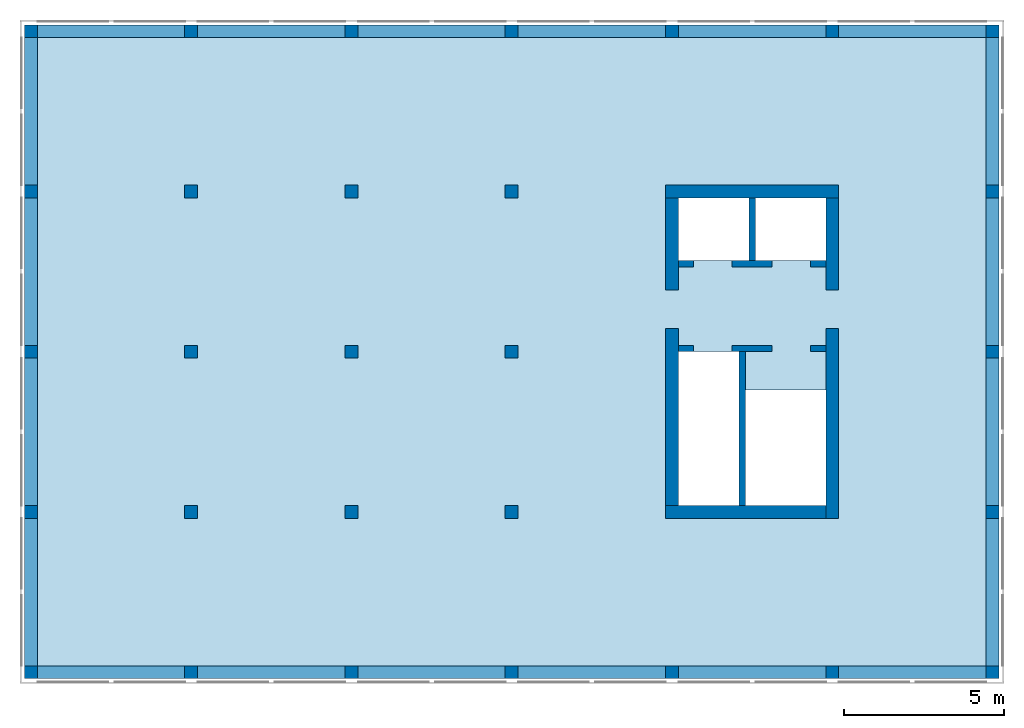
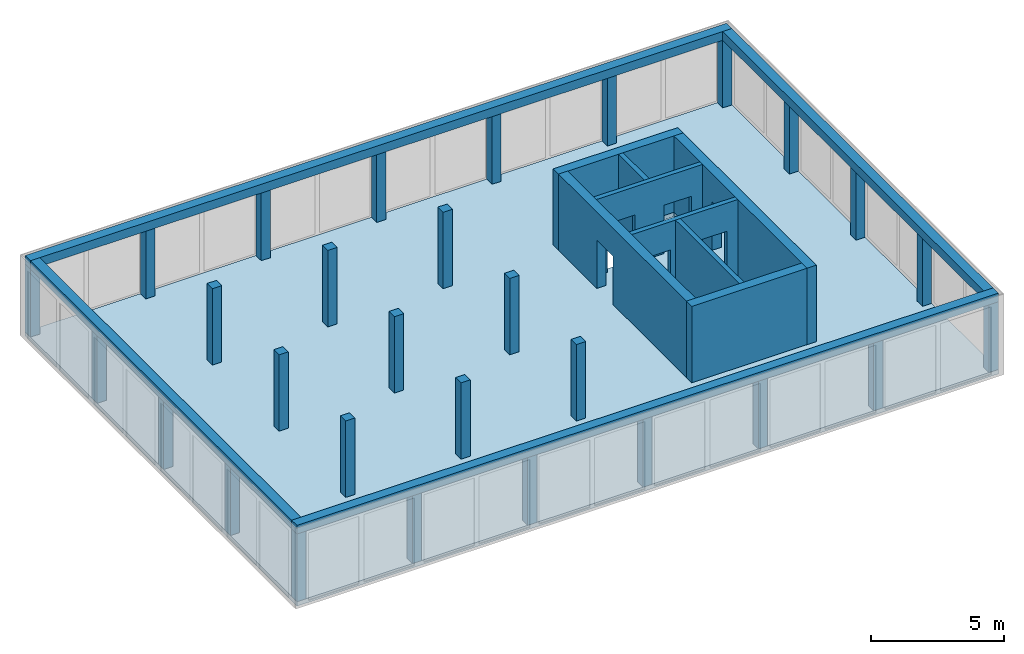
# One storey, part 1 of 3: 29 columns, 8 walls, 4 beams, 1 slab, 9 openings.
"""IFC2X3 building model written with IfcOpenShell, lengths in metres."""

from ifc_helpers import new_model, entity, si_unit, converted_unit, frame, frame_2d, origin, origin_with_axes, place, context, subcontext, project, spatial, polyline, rectangle, outline, extrude, material, layer, layer_set, layer_usage, element, save


model = new_model("IFC2X3")

# Units and contexts
model_context = context("Model", 3, precision=1e-05, world=origin())
body_context = subcontext(model_context, "Body", "Model", "MODEL_VIEW")
ifc_project = project(units=[si_unit("LENGTHUNIT", "METRE"), si_unit("AREAUNIT", "SQUARE_METRE"), si_unit("VOLUMEUNIT", "CUBIC_METRE"), si_unit("MASSUNIT", "GRAM", prefix="KILO"), converted_unit("PLANEANGLEUNIT", "DEGREE", entity("IfcPlaneAngleMeasure", 0.0174532925199433), si_unit("PLANEANGLEUNIT", "RADIAN"), dimensions=[0, 0, 0, 0, 0, 0, 0])], contexts=[model_context])

# Site, building, storey
site_placement = place(None, origin())
site = spatial("IfcSite", under=ifc_project, at=site_placement, CompositionType="ELEMENT")
building_placement = place(site_placement, origin())
building = spatial("IfcBuilding", under=site, at=building_placement, CompositionType="ELEMENT")
storey_placement = place(building_placement, frame((0.0, 0.0, 16.0)))
storey = spatial("IfcBuildingStorey", under=building, at=storey_placement, Name="4. Obergeschoss", CompositionType="ELEMENT", Elevation=16.0)

# Columns
ifc_material_1 = material(Name="C30/37")
column_1_placement = place(storey_placement, frame((5.0, 5.0, 0.0)))
element("IfcColumn", 1, at=column_1_placement, inside=storey, material=ifc_material_1, context=body_context, shape_type="SweptSolid", body=[
    extrude(rectangle(XDim=0.4, YDim=0.4, at=frame_2d((0.2, 0.2), x_axis=(1.0, 0.0))), origin_with_axes(), (0.0, 0.0, 1.0), 3.5),
])
ifc_material_2 = material(Name="C30/37")
column_2_placement = place(storey_placement, frame((15.0, 15.0, 0.0)))
element("IfcColumn", 2, at=column_2_placement, inside=storey, material=ifc_material_2, context=body_context, shape_type="SweptSolid", body=[
    extrude(rectangle(XDim=0.4, YDim=0.4, at=frame_2d((0.2, 0.2), x_axis=(1.0, 0.0))), origin_with_axes(), (0.0, 0.0, 1.0), 3.5),
])
ifc_material_3 = material(Name="C30/37")
column_3_placement = place(storey_placement, frame((10.0, 15.0, 0.0)))
element("IfcColumn", 3, at=column_3_placement, inside=storey, material=ifc_material_3, context=body_context, shape_type="SweptSolid", body=[
    extrude(rectangle(XDim=0.4, YDim=0.4, at=frame_2d((0.2, 0.2), x_axis=(1.0, 0.0))), origin_with_axes(), (0.0, 0.0, 1.0), 3.5),
])
ifc_material_4 = material(Name="C30/37")
column_4_placement = place(storey_placement, frame((5.0, 15.0, 0.0)))
element("IfcColumn", 4, at=column_4_placement, inside=storey, material=ifc_material_4, context=body_context, shape_type="SweptSolid", body=[
    extrude(rectangle(XDim=0.4, YDim=0.4, at=frame_2d((0.2, 0.2), x_axis=(1.0, 0.0))), origin_with_axes(), (0.0, 0.0, 1.0), 3.5),
])
ifc_material_5 = material(Name="C30/37")
column_5_placement = place(storey_placement, frame((15.0, 10.0, 0.0)))
element("IfcColumn", 5, at=column_5_placement, inside=storey, material=ifc_material_5, context=body_context, shape_type="SweptSolid", body=[
    extrude(rectangle(XDim=0.4, YDim=0.4, at=frame_2d((0.2, 0.2), x_axis=(1.0, 0.0))), origin_with_axes(), (0.0, 0.0, 1.0), 3.5),
])
ifc_material_6 = material(Name="C30/37")
column_6_placement = place(storey_placement, frame((10.0, 10.0, 0.0)))
element("IfcColumn", 6, at=column_6_placement, inside=storey, material=ifc_material_6, context=body_context, shape_type="SweptSolid", body=[
    extrude(rectangle(XDim=0.4, YDim=0.4, at=frame_2d((0.2, 0.2), x_axis=(1.0, 0.0))), origin_with_axes(), (0.0, 0.0, 1.0), 3.5),
])
ifc_material_7 = material(Name="C30/37")
column_7_placement = place(storey_placement, frame((5.0, 10.0, 0.0)))
element("IfcColumn", 7, at=column_7_placement, inside=storey, material=ifc_material_7, context=body_context, shape_type="SweptSolid", body=[
    extrude(rectangle(XDim=0.4, YDim=0.4, at=frame_2d((0.2, 0.2), x_axis=(1.0, 0.0))), origin_with_axes(), (0.0, 0.0, 1.0), 3.5),
])
ifc_material_8 = material(Name="C30/37")
column_8_placement = place(storey_placement, frame((15.0, 5.0, 0.0)))
element("IfcColumn", 8, at=column_8_placement, inside=storey, material=ifc_material_8, context=body_context, shape_type="SweptSolid", body=[
    extrude(rectangle(XDim=0.4, YDim=0.4, at=frame_2d((0.2, 0.2), x_axis=(1.0, 0.0))), origin_with_axes(), (0.0, 0.0, 1.0), 3.5),
])
ifc_material_9 = material(Name="C30/37")
column_9_placement = place(storey_placement, frame((10.0, 5.0, 0.0)))
element("IfcColumn", 9, at=column_9_placement, inside=storey, material=ifc_material_9, context=body_context, shape_type="SweptSolid", body=[
    extrude(rectangle(XDim=0.4, YDim=0.4, at=frame_2d((0.2, 0.2), x_axis=(1.0, 0.0))), origin_with_axes(), (0.0, 0.0, 1.0), 3.5),
])
ifc_material_10 = material(Name="C30/37")
column_10_placement = place(storey_placement, frame((-1.27897692436818e-15, 10.0, 0.0)))
element("IfcColumn", 10, at=column_10_placement, inside=storey, material=ifc_material_10, context=body_context, shape_type="SweptSolid", body=[
    extrude(rectangle(XDim=0.400000000000003, YDim=0.4, at=frame_2d((0.200000000000001, 0.2), x_axis=(1.0, 0.0))), origin_with_axes(), (0.0, 0.0, 1.0), 3.1),
])
ifc_material_11 = material(Name="C30/37")
column_11_placement = place(storey_placement, origin())
element("IfcColumn", 11, at=column_11_placement, inside=storey, material=ifc_material_11, context=body_context, shape_type="SweptSolid", body=[
    extrude(rectangle(XDim=0.4, YDim=0.4, at=frame_2d((0.2, 0.2), x_axis=(1.0, 0.0))), origin_with_axes(), (0.0, 0.0, 1.0), 3.1),
])
ifc_material_12 = material(Name="C30/37")
column_12_placement = place(storey_placement, frame((0.0, 15.0, 0.0)))
element("IfcColumn", 12, at=column_12_placement, inside=storey, material=ifc_material_12, context=body_context, shape_type="SweptSolid", body=[
    extrude(rectangle(XDim=0.4, YDim=0.4, at=frame_2d((0.2, 0.2), x_axis=(1.0, 0.0))), origin_with_axes(), (0.0, 0.0, 1.0), 3.1),
])
ifc_material_13 = material(Name="C30/37")
column_13_placement = place(storey_placement, frame((0.0, 5.0, 0.0)))
element("IfcColumn", 13, at=column_13_placement, inside=storey, material=ifc_material_13, context=body_context, shape_type="SweptSolid", body=[
    extrude(rectangle(XDim=0.4, YDim=0.4, at=frame_2d((0.2, 0.2), x_axis=(1.0, 0.0))), origin_with_axes(), (0.0, 0.0, 1.0), 3.1),
])
ifc_material_14 = material(Name="C30/37")
column_14_placement = place(storey_placement, frame((0.0, 20.0, 0.0)))
element("IfcColumn", 14, at=column_14_placement, inside=storey, material=ifc_material_14, context=body_context, shape_type="SweptSolid", body=[
    extrude(rectangle(XDim=0.4, YDim=0.4, at=frame_2d((0.2, 0.2), x_axis=(1.0, 0.0))), origin_with_axes(), (0.0, 0.0, 1.0), 3.1),
])
ifc_material_15 = material(Name="C30/37")
column_15_placement = place(storey_placement, frame((30.0, -2.8421709430404e-17, 0.0)))
element("IfcColumn", 15, at=column_15_placement, inside=storey, material=ifc_material_15, context=body_context, shape_type="SweptSolid", body=[
    extrude(rectangle(XDim=0.4, YDim=0.4, at=frame_2d((0.2, 0.2), x_axis=(1.0, 0.0))), origin_with_axes(), (0.0, 0.0, 1.0), 3.1),
])
ifc_material_16 = material(Name="C30/37")
column_16_placement = place(storey_placement, frame((30.0, 20.0, 0.0)))
element("IfcColumn", 16, at=column_16_placement, inside=storey, material=ifc_material_16, context=body_context, shape_type="SweptSolid", body=[
    extrude(rectangle(XDim=0.4, YDim=0.4, at=frame_2d((0.2, 0.2), x_axis=(1.0, 0.0))), origin_with_axes(), (0.0, 0.0, 1.0), 3.1),
])
ifc_material_17 = material(Name="C30/37")
column_17_placement = place(storey_placement, frame((30.0, 15.0, 0.0)))
element("IfcColumn", 17, at=column_17_placement, inside=storey, material=ifc_material_17, context=body_context, shape_type="SweptSolid", body=[
    extrude(rectangle(XDim=0.4, YDim=0.4, at=frame_2d((0.2, 0.2), x_axis=(1.0, 0.0))), origin_with_axes(), (0.0, 0.0, 1.0), 3.1),
])
ifc_material_18 = material(Name="C30/37")
column_18_placement = place(storey_placement, frame((30.0, 10.0, 0.0)))
element("IfcColumn", 18, at=column_18_placement, inside=storey, material=ifc_material_18, context=body_context, shape_type="SweptSolid", body=[
    extrude(rectangle(XDim=0.4, YDim=0.4, at=frame_2d((0.2, 0.2), x_axis=(1.0, 0.0))), origin_with_axes(), (0.0, 0.0, 1.0), 3.1),
])
ifc_material_19 = material(Name="C30/37")
column_19_placement = place(storey_placement, frame((30.0, 5.0, 0.0)))
element("IfcColumn", 19, at=column_19_placement, inside=storey, material=ifc_material_19, context=body_context, shape_type="SweptSolid", body=[
    extrude(rectangle(XDim=0.4, YDim=0.4, at=frame_2d((0.2, 0.2), x_axis=(1.0, 0.0))), origin_with_axes(), (0.0, 0.0, 1.0), 3.1),
])
ifc_material_20 = material(Name="C30/37")
column_20_placement = place(storey_placement, frame((25.0, 0.0, 0.0)))
element("IfcColumn", 20, at=column_20_placement, inside=storey, material=ifc_material_20, context=body_context, shape_type="SweptSolid", body=[
    extrude(rectangle(XDim=0.4, YDim=0.4, at=frame_2d((0.2, 0.2), x_axis=(1.0, 0.0))), origin_with_axes(), (0.0, 0.0, 1.0), 3.1),
])
ifc_material_21 = material(Name="C30/37")
column_21_placement = place(storey_placement, frame((20.0, 0.0, 0.0)))
element("IfcColumn", 21, at=column_21_placement, inside=storey, material=ifc_material_21, context=body_context, shape_type="SweptSolid", body=[
    extrude(rectangle(XDim=0.4, YDim=0.4, at=frame_2d((0.2, 0.2), x_axis=(1.0, 0.0))), origin_with_axes(), (0.0, 0.0, 1.0), 3.1),
])
ifc_material_22 = material(Name="C30/37")
column_22_placement = place(storey_placement, frame((5.0, 0.0, 0.0)))
element("IfcColumn", 22, at=column_22_placement, inside=storey, material=ifc_material_22, context=body_context, shape_type="SweptSolid", body=[
    extrude(rectangle(XDim=0.4, YDim=0.4, at=frame_2d((0.2, 0.2), x_axis=(1.0, 0.0))), origin_with_axes(), (0.0, 0.0, 1.0), 3.1),
])
ifc_material_23 = material(Name="C30/37")
column_23_placement = place(storey_placement, frame((20.0, 20.0, 0.0)))
element("IfcColumn", 23, at=column_23_placement, inside=storey, material=ifc_material_23, context=body_context, shape_type="SweptSolid", body=[
    extrude(rectangle(XDim=0.4, YDim=0.4, at=frame_2d((0.2, 0.2), x_axis=(1.0, 0.0))), origin_with_axes(), (0.0, 0.0, 1.0), 3.1),
])
ifc_material_24 = material(Name="C30/37")
column_24_placement = place(storey_placement, frame((15.0, 20.0, 0.0)))
element("IfcColumn", 24, at=column_24_placement, inside=storey, material=ifc_material_24, context=body_context, shape_type="SweptSolid", body=[
    extrude(rectangle(XDim=0.4, YDim=0.4, at=frame_2d((0.2, 0.2), x_axis=(1.0, 0.0))), origin_with_axes(), (0.0, 0.0, 1.0), 3.1),
])
ifc_material_25 = material(Name="C30/37")
column_25_placement = place(storey_placement, frame((10.0, 20.0, 0.0)))
element("IfcColumn", 25, at=column_25_placement, inside=storey, material=ifc_material_25, context=body_context, shape_type="SweptSolid", body=[
    extrude(rectangle(XDim=0.4, YDim=0.4, at=frame_2d((0.2, 0.2), x_axis=(1.0, 0.0))), origin_with_axes(), (0.0, 0.0, 1.0), 3.1),
])
ifc_material_26 = material(Name="C30/37")
column_26_placement = place(storey_placement, frame((5.0, 20.0, 0.0)))
element("IfcColumn", 26, at=column_26_placement, inside=storey, material=ifc_material_26, context=body_context, shape_type="SweptSolid", body=[
    extrude(rectangle(XDim=0.4, YDim=0.4, at=frame_2d((0.2, 0.2), x_axis=(1.0, 0.0))), origin_with_axes(), (0.0, 0.0, 1.0), 3.1),
])
ifc_material_27 = material(Name="C30/37")
column_27_placement = place(storey_placement, frame((25.0, 20.0, 0.0)))
element("IfcColumn", 27, at=column_27_placement, inside=storey, material=ifc_material_27, context=body_context, shape_type="SweptSolid", body=[
    extrude(rectangle(XDim=0.4, YDim=0.4, at=frame_2d((0.2, 0.2), x_axis=(1.0, 0.0))), origin_with_axes(), (0.0, 0.0, 1.0), 3.1),
])
ifc_material_28 = material(Name="C30/37")
column_28_placement = place(storey_placement, frame((15.0, 0.0, 0.0)))
element("IfcColumn", 28, at=column_28_placement, inside=storey, material=ifc_material_28, context=body_context, shape_type="SweptSolid", body=[
    extrude(rectangle(XDim=0.4, YDim=0.4, at=frame_2d((0.2, 0.2), x_axis=(1.0, 0.0))), origin_with_axes(), (0.0, 0.0, 1.0), 3.1),
])
ifc_material_29 = material(Name="C30/37")
column_29_placement = place(storey_placement, frame((10.0, 0.0, 0.0)))
element("IfcColumn", 29, at=column_29_placement, inside=storey, material=ifc_material_29, context=body_context, shape_type="SweptSolid", body=[
    extrude(rectangle(XDim=0.4, YDim=0.4, at=frame_2d((0.2, 0.2), x_axis=(1.0, 0.0))), origin_with_axes(), (0.0, 0.0, 1.0), 3.1),
])

# Beams
ifc_material_30 = material(Name="C30/37")
beam_1_placement = place(storey_placement, frame((2.95817792030736e-17, 2.8421709430404e-17, 3.1), z_axis=(0.0, 0.0, 1.0), x_axis=(1.0, -1.86984930463184e-18, 0.0)))
element("IfcBeam", 30, at=beam_1_placement, inside=storey, material=ifc_material_30, context=body_context, shape_type="SweptSolid", body=[
    extrude(rectangle(XDim=0.4, YDim=0.4, at=frame_2d((0.2, 0.2), x_axis=(1.0, 0.0))), frame((0.0, 0.0, 0.0), z_axis=(1.0, 0.0, 0.0), x_axis=(0.0, 1.0, 0.0)), (0.0, 0.0, 1.0), 30.4),
])
ifc_material_31 = material(Name="C30/37")
beam_2_placement = place(storey_placement, frame((-2.8421709430404e-17, 20.0, 3.1)))
element("IfcBeam", 31, at=beam_2_placement, inside=storey, material=ifc_material_31, context=body_context, shape_type="SweptSolid", body=[
    extrude(rectangle(XDim=0.4, YDim=0.4, at=frame_2d((0.2, 0.2), x_axis=(1.0, 0.0))), frame((0.0, 0.0, 0.0), z_axis=(1.0, 0.0, 0.0), x_axis=(0.0, 1.0, 0.0)), (0.0, 0.0, 1.0), 30.4),
])
ifc_material_32 = material(Name="C30/37")
beam_3_placement = place(storey_placement, frame((30.4, 0.4, 3.1), z_axis=(0.0, 0.0, 1.0), x_axis=(0.0, 1.0, 0.0)))
element("IfcBeam", 32, at=beam_3_placement, inside=storey, material=ifc_material_32, context=body_context, shape_type="SweptSolid", body=[
    extrude(rectangle(XDim=0.4, YDim=0.4, at=frame_2d((0.2, 0.2), x_axis=(1.0, 0.0))), frame((0.0, 0.0, 0.0), z_axis=(1.0, 0.0, 0.0), x_axis=(0.0, 1.0, 0.0)), (0.0, 0.0, 1.0), 19.6),
])
ifc_material_33 = material(Name="C30/37")
beam_4_placement = place(storey_placement, frame((-2.8421709430404e-17, 20.0, 3.1), z_axis=(0.0, 0.0, 1.0), x_axis=(2.90017443167388e-18, -1.0, 0.0)))
element("IfcBeam", 33, at=beam_4_placement, inside=storey, material=ifc_material_33, context=body_context, shape_type="SweptSolid", body=[
    extrude(rectangle(XDim=0.4, YDim=0.4, at=frame_2d((0.2, 0.2), x_axis=(1.0, 0.0))), frame((0.0, 0.0, 0.0), z_axis=(1.0, 0.0, 0.0), x_axis=(0.0, 1.0, 0.0)), (0.0, 0.0, 1.0), 19.6),
])

# Slab, openings
ifc_material_34 = material(Name="C25/30")
slab_placement = place(storey_placement, frame((0.0, 0.0, -0.2)))
slab = element("IfcSlab", 34, at=slab_placement, inside=storey, material=ifc_material_34, Name="Geschossdecke", PredefinedType="FLOOR", context=body_context, shape_type="SweptSolid", body=[
    extrude(rectangle(XDim=30.4, YDim=20.4, at=frame_2d((15.2, 10.2), x_axis=(1.0, 0.0))), origin_with_axes(), (0.0, 0.0, 1.0), 0.2),
])
opening_1_placement = place(slab_placement, frame((20.4, 5.4, 0.0)))
element("IfcOpeningElement", 35, at=opening_1_placement, cuts=slab, ObjectType="Opening", context=body_context, shape_type="SweptSolid", body=[
    extrude(rectangle(XDim=4.8, YDim=2.1, at=frame_2d((1.81898940354586e-15, 0.0), x_axis=(0.0, -1.0))), frame((1.05, 2.4, 0.0), z_axis=(0.0, 0.0, 1.0), x_axis=(1.0, 0.0, 0.0)), (0.0, 0.0, 1.0), 0.2),
])
opening_2_placement = place(slab_placement, frame((22.5, 5.4, 0.0)))
element("IfcOpeningElement", 36, at=opening_2_placement, cuts=slab, ObjectType="Opening", context=body_context, shape_type="SweptSolid", body=[
    extrude(rectangle(XDim=2.5, YDim=3.6, at=frame_2d((0.0, 0.0), x_axis=(-1.0, 0.0))), frame((1.25, 1.8, 0.0), z_axis=(0.0, 0.0, 1.0), x_axis=(1.0, 0.0, 0.0)), (0.0, 0.0, 1.0), 0.2),
])
opening_3_placement = place(slab_placement, frame((20.4, 13.05, 0.0)))
element("IfcOpeningElement", 37, at=opening_3_placement, cuts=slab, ObjectType="Opening", context=body_context, shape_type="SweptSolid", body=[
    extrude(rectangle(XDim=1.95, YDim=4.6, at=frame_2d((1.81898940354586e-15, 0.0), x_axis=(0.0, -1.0))), frame((2.3, 0.975, 0.0), z_axis=(0.0, 0.0, 1.0), x_axis=(1.0, 0.0, 0.0)), (0.0, 0.0, 1.0), 0.2),
])

# Wall
ifc_material_35 = material(Name="C25/30")
ifc_layer_1 = layer(ifc_material_35, 0.2)
ifc_layer_set_1 = layer_set([ifc_layer_1])
ifc_layer_usage_1 = layer_usage(ifc_layer_set_1, "AXIS2", "POSITIVE", -0.2)
wall_1_placement = place(storey_placement, frame((22.3, 10.2, 0.0), z_axis=(0.0, 0.0, 1.0), x_axis=(0.0, -1.0, 0.0)))
element("IfcWallStandardCase", 38, at=wall_1_placement, inside=storey, material=ifc_layer_usage_1, Name="IW Beton", context=body_context, shape_type="SweptSolid", body=[
    extrude(rectangle(XDim=4.8, YDim=0.2, at=frame_2d((2.4, 0.1), x_axis=(1.0, 0.0))), origin_with_axes(), (0.0, 0.0, 1.0), 3.5),
])

# Wall, openings
ifc_material_36 = material(Name="C25/30")
ifc_layer_2 = layer(ifc_material_36, 0.2)
ifc_layer_set_2 = layer_set([ifc_layer_2])
ifc_layer_usage_2 = layer_usage(ifc_layer_set_2, "AXIS2", "POSITIVE", -0.2)
wall_2_placement = place(storey_placement, frame((25.0, 10.4, 0.0), z_axis=(0.0, 0.0, 1.0), x_axis=(-1.0, 0.0, 0.0)))
wall_2 = element("IfcWallStandardCase", 39, at=wall_2_placement, inside=storey, material=ifc_layer_usage_2, Name="IW Beton", context=body_context, shape_type="SweptSolid", body=[
    extrude(rectangle(XDim=4.6, YDim=0.2, at=frame_2d((2.3, 0.1), x_axis=(1.0, 0.0))), origin_with_axes(), (0.0, 0.0, 1.0), 3.5),
])
opening_4_placement = place(wall_2_placement, frame((4.13, 0.2, 0.0), z_axis=(0.0, -1.0, 0.0), x_axis=(0.0, 0.0, 1.0)))
element("IfcOpeningElement", 40, at=opening_4_placement, cuts=wall_2, ObjectType="Opening", context=body_context, shape_type="SweptSolid", body=[
    extrude(outline(polyline([(0.0, 1.21), (2.21, 1.21), (2.21, 0.0), (0.0, 0.0), (0.0, 1.21)])), origin_with_axes(), (0.0, 0.0, 1.0), 0.2),
])
opening_5_placement = place(wall_2_placement, frame((1.68, 0.2, 0.0), z_axis=(0.0, -1.0, 0.0), x_axis=(0.0, 0.0, 1.0)))
element("IfcOpeningElement", 41, at=opening_5_placement, cuts=wall_2, ObjectType="Opening", context=body_context, shape_type="SweptSolid", body=[
    extrude(outline(polyline([(0.0, 1.21), (2.21, 1.21), (2.21, 0.0), (0.0, 0.0), (0.0, 1.21)])), origin_with_axes(), (0.0, 0.0, 1.0), 0.2),
])

ifc_material_37 = material(Name="C25/30")
ifc_layer_3 = layer(ifc_material_37, 0.2)
ifc_layer_set_3 = layer_set([ifc_layer_3])
ifc_layer_usage_3 = layer_usage(ifc_layer_set_3, "AXIS2", "POSITIVE", -0.2)
wall_3_placement = place(storey_placement, frame((25.0, 13.05, 0.0), z_axis=(0.0, 0.0, 1.0), x_axis=(-1.0, 0.0, 0.0)))
wall_3 = element("IfcWallStandardCase", 42, at=wall_3_placement, inside=storey, material=ifc_layer_usage_3, Name="IW Beton", context=body_context, shape_type="SweptSolid", body=[
    extrude(rectangle(XDim=4.6, YDim=0.2, at=frame_2d((2.3, 0.1), x_axis=(1.0, 0.0))), origin_with_axes(), (0.0, 0.0, 1.0), 3.5),
])
opening_6_placement = place(wall_3_placement, frame((4.13, 0.2, 0.0), z_axis=(0.0, -1.0, 0.0), x_axis=(0.0, 0.0, 1.0)))
element("IfcOpeningElement", 43, at=opening_6_placement, cuts=wall_3, ObjectType="Opening", context=body_context, shape_type="SweptSolid", body=[
    extrude(outline(polyline([(0.0, 1.21), (2.21, 1.21), (2.21, 0.0), (0.0, 0.0), (0.0, 1.21)])), origin_with_axes(), (0.0, 0.0, 1.0), 0.2),
])
opening_7_placement = place(wall_3_placement, frame((1.68, 0.2, 0.0), z_axis=(0.0, -1.0, 0.0), x_axis=(0.0, 0.0, 1.0)))
element("IfcOpeningElement", 44, at=opening_7_placement, cuts=wall_3, ObjectType="Opening", context=body_context, shape_type="SweptSolid", body=[
    extrude(outline(polyline([(0.0, 1.21), (2.21, 1.21), (2.21, 0.0), (0.0, 0.0), (0.0, 1.21)])), origin_with_axes(), (0.0, 0.0, 1.0), 0.2),
])

# Wall
ifc_material_38 = material(Name="C25/30")
ifc_layer_4 = layer(ifc_material_38, 0.2)
ifc_layer_set_4 = layer_set([ifc_layer_4])
ifc_layer_usage_4 = layer_usage(ifc_layer_set_4, "AXIS2", "POSITIVE", -0.2)
wall_4_placement = place(storey_placement, frame((22.6, 15.0, 0.0), z_axis=(0.0, 0.0, 1.0), x_axis=(0.0, -1.0, 0.0)))
element("IfcWallStandardCase", 45, at=wall_4_placement, inside=storey, material=ifc_layer_usage_4, Name="IW Beton", context=body_context, shape_type="SweptSolid", body=[
    extrude(rectangle(XDim=1.95, YDim=0.2, at=frame_2d((0.975, 0.1), x_axis=(1.0, 0.0))), origin_with_axes(), (0.0, 0.0, 1.0), 3.5),
])

# Wall, opening
ifc_material_39 = material(Name="C25/30")
ifc_layer_5 = layer(ifc_material_39, 0.4)
ifc_layer_set_5 = layer_set([ifc_layer_5])
ifc_layer_usage_5 = layer_usage(ifc_layer_set_5, "AXIS2", "POSITIVE", -0.2)
wall_5_placement = place(storey_placement, frame((25.0, 15.0, 0.0), z_axis=(0.0, 0.0, 1.0), x_axis=(0.0, -1.0, 0.0)))
wall_5 = element("IfcWallStandardCase", 46, at=wall_5_placement, inside=storey, material=ifc_layer_usage_5, context=body_context, shape_type="SweptSolid", body=[
    extrude(rectangle(XDim=10.0, YDim=0.4, at=frame_2d((5.0, 0.2), x_axis=(1.0, 0.0))), origin_with_axes(), (0.0, 0.0, 1.0), 3.5),
])
opening_8_placement = place(wall_5_placement, frame((2.87, 0.0, 0.0), z_axis=(0.0, 1.0, 0.0), x_axis=(0.0, 0.0, 1.0)))
element("IfcOpeningElement", 47, at=opening_8_placement, cuts=wall_5, ObjectType="Opening", context=body_context, shape_type="SweptSolid", body=[
    extrude(outline(polyline([(0.0, 1.21), (2.21, 1.21), (2.21, 0.0), (0.0, 0.0), (0.0, 1.21)])), origin_with_axes(), (0.0, 0.0, 1.0), 0.4),
])

# Wall
ifc_material_40 = material(Name="C25/30")
ifc_layer_6 = layer(ifc_material_40, 0.4)
ifc_layer_set_6 = layer_set([ifc_layer_6])
ifc_layer_usage_6 = layer_usage(ifc_layer_set_6, "AXIS2", "POSITIVE", -0.2)
wall_6_placement = place(storey_placement, frame((20.0, 15.0, 0.0)))
element("IfcWallStandardCase", 48, at=wall_6_placement, inside=storey, material=ifc_layer_usage_6, context=body_context, shape_type="SweptSolid", body=[
    extrude(rectangle(XDim=5.4, YDim=0.4, at=frame_2d((2.7, 0.2), x_axis=(1.0, 0.0))), origin_with_axes(), (0.0, 0.0, 1.0), 3.5),
])

# Wall, opening
ifc_material_41 = material(Name="C25/30")
ifc_layer_7 = layer(ifc_material_41, 0.4)
ifc_layer_set_7 = layer_set([ifc_layer_7])
ifc_layer_usage_7 = layer_usage(ifc_layer_set_7, "AXIS2", "POSITIVE", -0.2)
wall_7_placement = place(storey_placement, frame((20.4, 5.4, 0.0), z_axis=(0.0, 0.0, 1.0), x_axis=(0.0, 1.0, 0.0)))
wall_7 = element("IfcWallStandardCase", 49, at=wall_7_placement, inside=storey, material=ifc_layer_usage_7, context=body_context, shape_type="SweptSolid", body=[
    extrude(rectangle(XDim=9.6, YDim=0.4, at=frame_2d((4.8, 0.2), x_axis=(1.0, 0.0))), origin_with_axes(), (0.0, 0.0, 1.0), 3.5),
])
opening_9_placement = place(wall_7_placement, frame((5.52, 0.0, 0.0), z_axis=(0.0, 1.0, 0.0), x_axis=(0.0, 0.0, 1.0)))
element("IfcOpeningElement", 50, at=opening_9_placement, cuts=wall_7, ObjectType="Opening", context=body_context, shape_type="SweptSolid", body=[
    extrude(outline(polyline([(0.0, 1.21), (2.21, 1.21), (2.21, 0.0), (0.0, 0.0), (0.0, 1.21)])), origin_with_axes(), (0.0, 0.0, 1.0), 0.4),
])

# Wall
ifc_material_42 = material(Name="C25/30")
ifc_layer_8 = layer(ifc_material_42, 0.4)
ifc_layer_set_8 = layer_set([ifc_layer_8])
ifc_layer_usage_8 = layer_usage(ifc_layer_set_8, "AXIS2", "POSITIVE", -0.2)
wall_8_placement = place(storey_placement, frame((25.0, 5.4, 0.0), z_axis=(0.0, 0.0, 1.0), x_axis=(-1.0, 0.0, 0.0)))
element("IfcWallStandardCase", 51, at=wall_8_placement, inside=storey, material=ifc_layer_usage_8, context=body_context, shape_type="SweptSolid", body=[
    extrude(rectangle(XDim=5.0, YDim=0.4, at=frame_2d((2.5, 0.2), x_axis=(1.0, 0.0))), origin_with_axes(), (0.0, 0.0, 1.0), 3.5),
])

save(model, "model.ifc")
